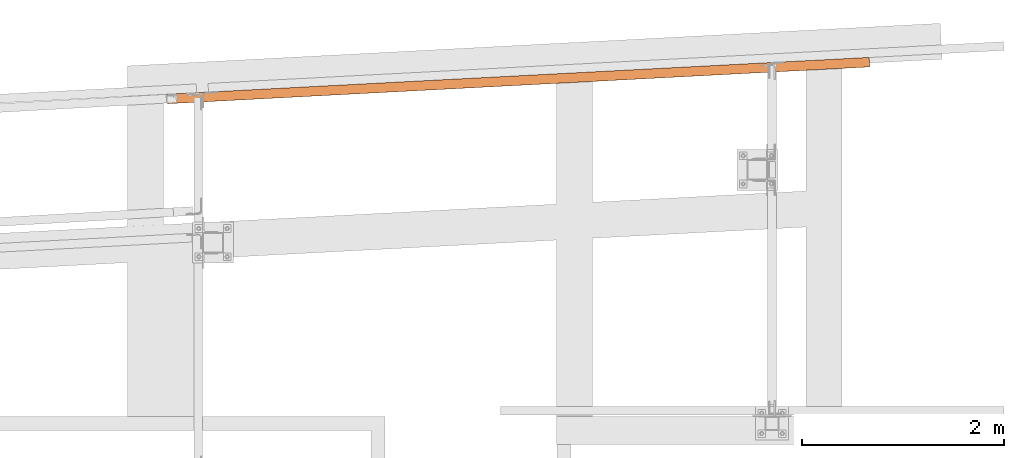
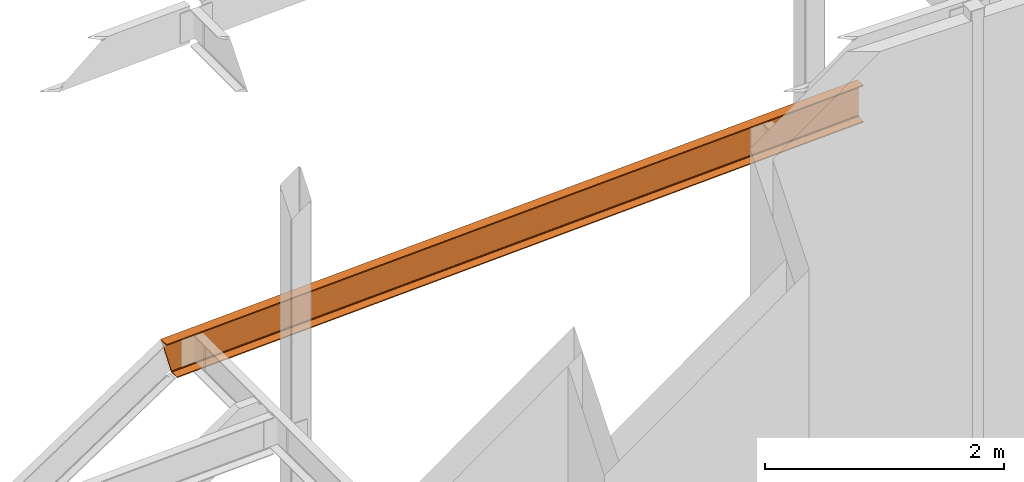
# One storey, part 21 of 89: 1 proxy.
"""IFC4 building model written with IfcOpenShell, lengths in feet."""

from ifc_helpers import new_model, entity, si_unit, converted_unit, derived_unit, direction, frame, origin, place, context, subcontext, project, spatial, faceted_brep, source, transform, mapped, material, constituent, constituent_set, type_object, type_shapes, element, save


model = new_model("IFC4")

# Units and contexts
model_context = context("Model", 3, precision=0.0001, world=origin(), true_north=direction((6.12303176911189e-17, 1.0)))
body_context = subcontext(model_context, "Body", "Model", "MODEL_VIEW")
ifc_project = project(units=[converted_unit("LENGTHUNIT", "FOOT", entity("IfcRatioMeasure", 0.3048), si_unit("LENGTHUNIT", "METRE"), dimensions=[1, 0, 0, 0, 0, 0, 0]), converted_unit("AREAUNIT", "SQUARE FOOT", entity("IfcRatioMeasure", 0.09290304), si_unit("AREAUNIT", "SQUARE_METRE"), dimensions=[2, 0, 0, 0, 0, 0, 0]), converted_unit("VOLUMEUNIT", "CUBIC FOOT", entity("IfcRatioMeasure", 0.028316846592), si_unit("VOLUMEUNIT", "CUBIC_METRE"), dimensions=[3, 0, 0, 0, 0, 0, 0]), si_unit("PLANEANGLEUNIT", "RADIAN"), si_unit("MASSUNIT", "GRAM", prefix="KILO"), derived_unit("MASSDENSITYUNIT", [(si_unit("MASSUNIT", "GRAM", prefix="KILO"), 1), (si_unit("LENGTHUNIT", "METRE"), -3)]), derived_unit("MOMENTOFINERTIAUNIT", [(si_unit("LENGTHUNIT", "METRE"), 4)]), si_unit("TIMEUNIT", "SECOND"), si_unit("FREQUENCYUNIT", "HERTZ"), si_unit("THERMODYNAMICTEMPERATUREUNIT", "DEGREE_CELSIUS"), derived_unit("THERMALTRANSMITTANCEUNIT", [(si_unit("MASSUNIT", "GRAM", prefix="KILO"), 1), (si_unit("THERMODYNAMICTEMPERATUREUNIT", "KELVIN"), -1), (si_unit("TIMEUNIT", "SECOND"), -3)]), derived_unit("VOLUMETRICFLOWRATEUNIT", [(si_unit("LENGTHUNIT", "METRE"), 3), (si_unit("TIMEUNIT", "SECOND"), -1)]), si_unit("ELECTRICCURRENTUNIT", "AMPERE"), si_unit("ELECTRICVOLTAGEUNIT", "VOLT"), si_unit("POWERUNIT", "WATT"), si_unit("FORCEUNIT", "NEWTON"), si_unit("ILLUMINANCEUNIT", "LUX"), si_unit("LUMINOUSFLUXUNIT", "LUMEN"), si_unit("LUMINOUSINTENSITYUNIT", "CANDELA"), derived_unit("USERDEFINED", [(si_unit("MASSUNIT", "GRAM", prefix="KILO"), -1), (si_unit("LENGTHUNIT", "METRE"), -2), (si_unit("TIMEUNIT", "SECOND"), 3), (si_unit("LUMINOUSFLUXUNIT", "LUMEN"), 1)]), derived_unit("LINEARVELOCITYUNIT", [(si_unit("LENGTHUNIT", "METRE"), 1), (si_unit("TIMEUNIT", "SECOND"), -1)]), si_unit("PRESSUREUNIT", "PASCAL"), derived_unit("USERDEFINED", [(si_unit("LENGTHUNIT", "METRE"), -2), (si_unit("MASSUNIT", "GRAM", prefix="KILO"), 1), (si_unit("TIMEUNIT", "SECOND"), -2)]), derived_unit("LINEARFORCEUNIT", [(si_unit("MASSUNIT", "GRAM", prefix="KILO"), 1), (si_unit("LENGTHUNIT", "METRE"), 1), (si_unit("TIMEUNIT", "SECOND"), -2), (si_unit("LENGTHUNIT", "METRE"), -1)]), derived_unit("PLANARFORCEUNIT", [(si_unit("MASSUNIT", "GRAM", prefix="KILO"), 1), (si_unit("LENGTHUNIT", "METRE"), 1), (si_unit("TIMEUNIT", "SECOND"), -2), (si_unit("LENGTHUNIT", "METRE"), -2)])], contexts=[model_context])

# Site, building, storey
site_placement = place(None, origin())
site = spatial("IfcSite", under=ifc_project, at=site_placement, CompositionType="ELEMENT")
building_placement = place(site_placement, frame((-472.238160486, -49.138065117, 0.0)))
building = spatial("IfcBuilding", under=site, at=building_placement, CompositionType="ELEMENT")
storey_placement = place(building_placement, origin())
storey = spatial("IfcBuildingStorey", under=building, at=storey_placement, Name="Level 1", CompositionType="ELEMENT", Elevation=0.0)

# Proxy
ifc_material_1 = material(Name="Color 7720", Category="Materials")
ifc_material_2 = material()
ifc_constituent_1 = constituent(ifc_material_2)
ifc_constituent_2 = constituent(ifc_material_1, Name="Color 7720", Category="Materials")
ifc_constituent_set = constituent_set(constituents=[ifc_constituent_1, ifc_constituent_2])
building_element_proxy_type = type_object("IfcBuildingElementProxyType", Name="32B1", PredefinedType="NOTDEFINED", material=ifc_constituent_set)
shared_shape = source(origin(), body_context, "Body", "Brep", [
    faceted_brep([(0.0, 0.309575155773928, 1.25), (0.344728042167674, 0.327641586920549, 0.0), (0.360952188603051, 0.0180664311466217, 0.0), (0.351766901923668, 0.0175850506697088, 0.0333062789933898), (0.331500020548162, 0.222983605981085, 0.0676680457191239), (0.328885631303876, 0.240281859141533, 0.073843741401685), (0.324889389002351, 0.254313426763929, 0.0856354543123707), (0.319999737147441, 0.26336329070466, 0.101601934112367), (0.314814316849152, 0.266325325028561, 0.119791666666654), (0.0361591494302616, 0.251721626518474, 1.13020833333334), (0.0313117523029405, 0.248233794513226, 1.14839806588763), (0.0273948548430667, 0.238722398879645, 1.16436454568762), (0.0248872025757692, 0.224349976586154, 1.17615625859832), (0.024095295049392, 0.206873206976638, 1.18233195428088), (0.0254094331148167, 0.000481380476912818, 1.21669372100661), (0.016224146435377, 0.0, 1.25000000000001), (22.8111017297626, 1.19462891317107, 1.25), (22.8111017297626, 1.19462891317107, 1.2166937210066), (22.8003112200422, 1.40052410407668, 1.18233195428088), (22.7993999791832, 1.41791161546155, 1.17615625859831), (22.7986556841661, 1.43211361041961, 1.16436454568763), (22.7981693069686, 1.44139424020671, 1.14839806588763), (22.7980002953831, 1.44461917337128, 1.13020833333334), (22.7980002953831, 1.44461917337128, 0.119791666666675), (22.7981693069686, 1.44139424020671, 0.101601934112374), (22.7986556841661, 1.43211361041961, 0.085635454312385), (22.7993999791832, 1.41791161546155, 0.0738437414016921), (22.8003112200422, 1.40052410407668, 0.0676680457191239), (22.8111017297626, 1.19462891317107, 0.033306278993404), (22.8111017297626, 1.19462891317107, 0.0), (22.7948775833273, 1.504204068945, 0.0), (22.7948775833273, 1.504204068945, 1.25)], [[[0, 1, 2, 3, 4, 5, 6, 7, 8, 9, 10, 11, 12, 13, 14, 15]], [[16, 17, 18, 19, 20, 21, 22, 23, 24, 25, 26, 27, 28, 29, 30, 31]], [[30, 1, 0, 31]], [[29, 2, 1, 30]], [[28, 3, 2, 29]], [[27, 4, 3, 28]], [[26, 5, 4, 27]], [[25, 6, 5, 26]], [[24, 7, 6, 25]], [[23, 8, 7, 24]], [[22, 9, 8, 23]], [[21, 10, 9, 22]], [[20, 11, 10, 21]], [[19, 12, 11, 20]], [[18, 13, 12, 19]], [[17, 14, 13, 18]], [[16, 15, 14, 17]], [[31, 0, 15, 16]]]),
])
type_shapes(building_element_proxy_type, [shared_shape])
proxy_placement = place(building_placement, frame((306.666666666666, 1018.14438538766, 19.0208333333333)))
element("IfcBuildingElementProxy", 1, at=proxy_placement, inside=storey, type_object=building_element_proxy_type, material=ifc_material_1, Name="32B1:32B1", ObjectType="32B1:32B1", PredefinedType="NOTDEFINED", context=body_context, shape_type="MappedRepresentation", body=[
    mapped(shared_shape, transform((0.0, 0.0, 0.0), scale=1.0)),
])

save(model, "model.ifc")
